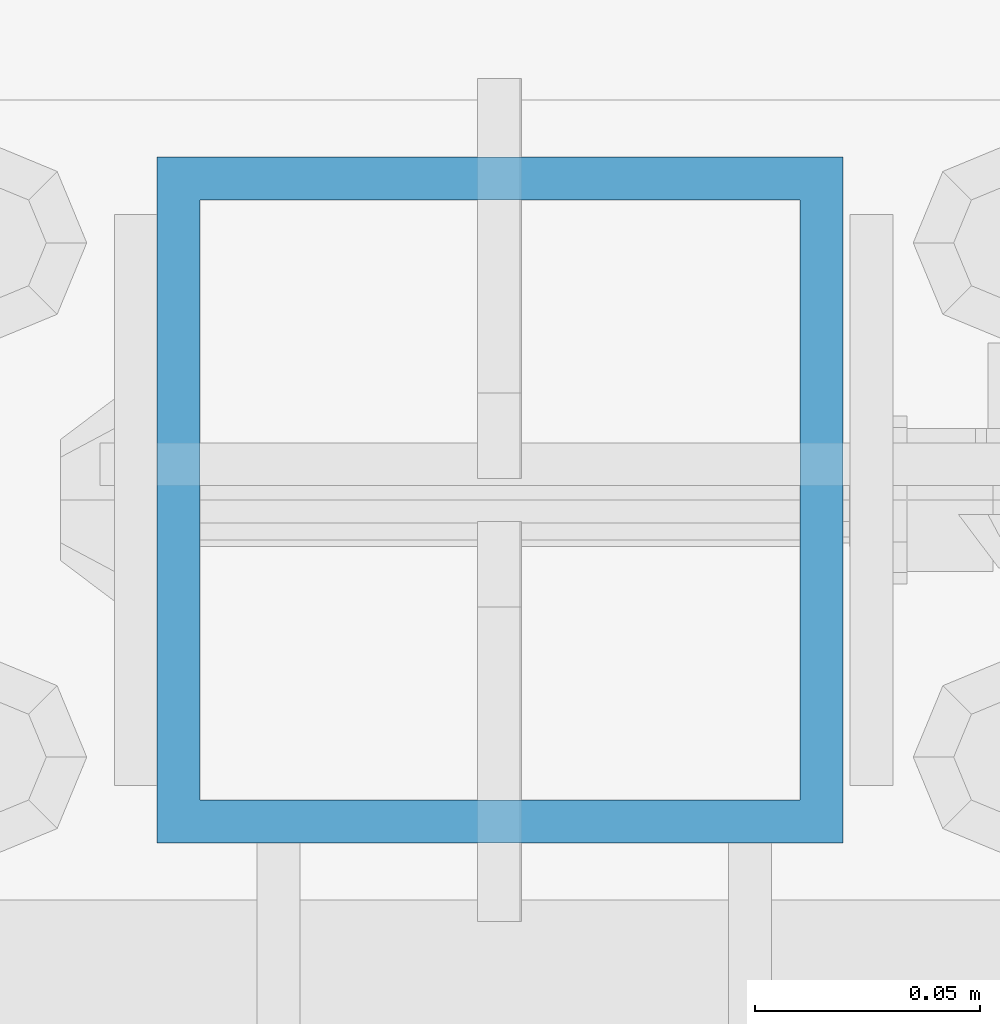
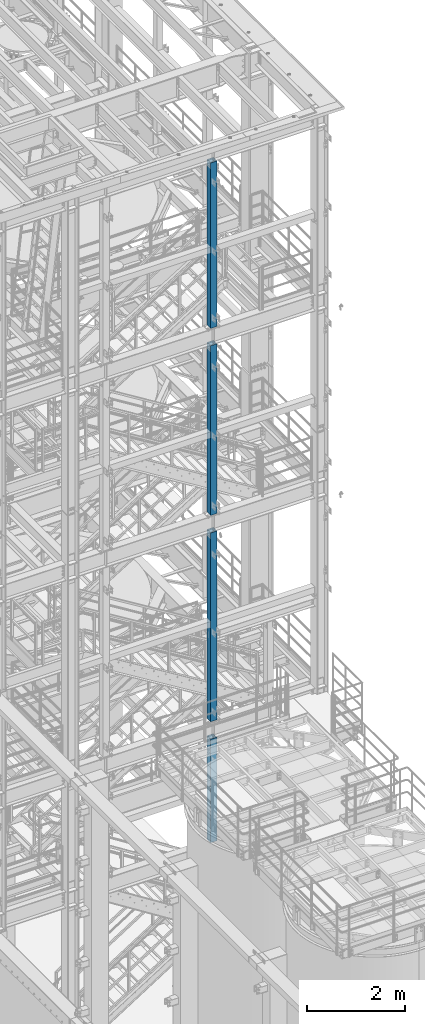
# One storey, part 579 of 1876: 4 columns, 4 elements without a shape of their own.
"""IFC2X3 building model written with IfcOpenShell, lengths in millimetres."""

from ifc_helpers import new_model, si_unit, frame, origin_with_axes, place, context, subcontext, project, spatial, faceted_brep, material, type_object, element, aggregate, save


model = new_model("IFC2X3")

# Units and contexts
model_context = context("Model", 3, precision=1e-05, world=origin_with_axes())
body_context = subcontext(model_context, "Body", "Model", "MODEL_VIEW")
ifc_project = project(units=[si_unit("LENGTHUNIT", "METRE", prefix="MILLI"), si_unit("AREAUNIT", "SQUARE_METRE"), si_unit("VOLUMEUNIT", "CUBIC_METRE"), si_unit("MASSUNIT", "GRAM", prefix="KILO"), si_unit("TIMEUNIT", "SECOND"), si_unit("PLANEANGLEUNIT", "RADIAN"), si_unit("SOLIDANGLEUNIT", "STERADIAN"), si_unit("THERMODYNAMICTEMPERATUREUNIT", "DEGREE_CELSIUS"), si_unit("LUMINOUSINTENSITYUNIT", "LUMEN")], contexts=[model_context])

# Site, building, storey
site_placement = place(None, origin_with_axes())
site = spatial("IfcSite", under=ifc_project, at=site_placement, CompositionType="ELEMENT")
building_placement = place(site_placement, origin_with_axes())
building = spatial("IfcBuilding", under=site, at=building_placement, Name="Undefined", CompositionType="ELEMENT")
storey_placement = place(building_placement, origin_with_axes())
storey = spatial("IfcBuildingStorey", under=building, at=storey_placement, Name="Undefined", CompositionType="ELEMENT", Elevation=0.0)

# Assembly, column
assembly_1_placement = place(storey_placement, origin_with_axes())
assembly_1 = element("IfcElementAssembly", 1, at=assembly_1_placement, inside=storey, Name="FRAME", AssemblyPlace="NOTDEFINED", PredefinedType="RIGID_FRAME")
ifc_material = material()
column_type = type_object("IfcColumnType", Name="HSS6X6X3/8", PredefinedType="NOTDEFINED")
column_1_placement = place(assembly_1_placement, frame((5080.0, -7112.0, 17983.2), z_axis=(-1.0, 0.0, 0.0), x_axis=(0.0, 0.0, 1.0)))
column_1 = element("IfcColumn", 2, at=column_1_placement, type_object=column_type, material=ifc_material, Name="COLUMN", ObjectType="HSS6X6X3/8", context=body_context, shape_type="Brep", body=[
    faceted_brep([(12.7000000000016, 66.6750000000002, -66.6750000000002), (12.7000000000016, -66.6750000000002, -66.6750000000002), (4149.72500000001, -66.6750000000002, -66.6750000000002), (4149.72500000001, 66.6750000000002, -66.6750000000002), (12.7000000000016, -66.6750000000002, 66.6750000000002), (4149.72500000001, -66.6750000000002, 66.6750000000002), (12.7000000000016, 66.6750000000002, 66.6750000000002), (4149.72500000001, 66.6750000000002, 66.6750000000002), (12.7000000000016, 76.1999999999998, -76.1999999999998), (12.7000000000016, 76.1999999999998, 76.1999999999998), (4149.72500000001, 76.1999999999998, 76.1999999999998), (4149.72500000001, 76.1999999999998, -76.1999999999998), (12.7000000000016, -76.1999999999998, 76.1999999999998), (4149.72500000001, -76.1999999999998, 76.1999999999998), (12.7000000000016, -76.1999999999998, -76.1999999999998), (4149.72500000001, -76.1999999999998, -76.1999999999998)], [[[0, 1, 2, 3]], [[1, 4, 5, 2]], [[4, 6, 7, 5]], [[6, 0, 3, 7]], [[8, 9, 10, 11]], [[9, 12, 13, 10]], [[12, 14, 15, 13]], [[14, 8, 11, 15]], [[13, 15, 11, 10], [5, 7, 3, 2]], [[14, 12, 9, 8], [6, 4, 1, 0]]]),
])
aggregate(assembly_1, [column_1])

assembly_2_placement = place(storey_placement, origin_with_axes())
assembly_2 = element("IfcElementAssembly", 3, at=assembly_2_placement, inside=storey, Name="FRAME", AssemblyPlace="NOTDEFINED", PredefinedType="RIGID_FRAME")
column_2_placement = place(assembly_2_placement, frame((5080.0, -7112.0, 13309.6), z_axis=(-1.0, 0.0, 0.0), x_axis=(0.0, 0.0, 1.0)))
column_2 = element("IfcColumn", 4, at=column_2_placement, type_object=column_type, material=ifc_material, Name="COLUMN", ObjectType="HSS6X6X3/8", context=body_context, shape_type="Brep", body=[
    faceted_brep([(12.7000000000016, 66.6750000000002, -66.6750000000002), (12.7000000000016, -66.6750000000002, -66.6750000000002), (4251.325, -66.6750000000002, -66.6750000000002), (4251.325, 66.6750000000002, -66.6750000000002), (12.7000000000016, -66.6750000000002, 66.6750000000002), (4251.325, -66.6750000000002, 66.6750000000002), (12.7000000000016, 66.6750000000002, 66.6750000000002), (4251.325, 66.6750000000002, 66.6750000000002), (12.7000000000016, 76.1999999999998, -76.1999999999998), (12.7000000000016, 76.1999999999998, 76.1999999999998), (4251.325, 76.1999999999998, 76.1999999999998), (4251.325, 76.1999999999998, -76.1999999999998), (12.7000000000016, -76.1999999999998, 76.1999999999998), (4251.325, -76.1999999999998, 76.1999999999998), (12.7000000000016, -76.1999999999998, -76.1999999999998), (4251.325, -76.1999999999998, -76.1999999999998)], [[[0, 1, 2, 3]], [[1, 4, 5, 2]], [[4, 6, 7, 5]], [[6, 0, 3, 7]], [[8, 9, 10, 11]], [[9, 12, 13, 10]], [[12, 14, 15, 13]], [[14, 8, 11, 15]], [[13, 15, 11, 10], [5, 7, 3, 2]], [[14, 12, 9, 8], [6, 4, 1, 0]]]),
])
aggregate(assembly_2, [column_2])

assembly_3_placement = place(storey_placement, origin_with_axes())
assembly_3 = element("IfcElementAssembly", 5, at=assembly_3_placement, inside=storey, Name="FRAME", AssemblyPlace="NOTDEFINED", PredefinedType="RIGID_FRAME")
column_3_placement = place(assembly_3_placement, frame((5080.0, -7112.0, 8153.4), z_axis=(-1.0, 0.0, 0.0), x_axis=(0.0, 0.0, 1.0)))
column_3 = element("IfcColumn", 6, at=column_3_placement, type_object=column_type, material=ifc_material, Name="COLUMN", ObjectType="HSS6X6X3/8", context=body_context, shape_type="Brep", body=[
    faceted_brep([(2062.16251831053, 1.58750109672837, 76.1999999999998), (2062.16251831053, 1.58750109672837, 66.6750000000002), (2062.16251831053, 14.2874999523192, 66.6750000000002), (2062.16251831053, 14.2874999523192, 76.1999999999998), (2217.73749999998, 14.2874999523192, 66.6750000000002), (2217.73749999998, 14.2874999523192, 76.1999999999998), (2217.73749999998, 1.58750109672837, 66.6750000000002), (2217.73749999998, 1.58750109672837, 76.1999999999998), (2062.16251831053, 1.58750109672837, -66.6750000000002), (2062.16251831053, 1.58750109672837, -76.1999999999998), (2062.16251831053, 14.2874999523192, -76.1999999999998), (2062.16251831053, 14.2874999523192, -66.6750000000002), (2217.73749999998, 14.2874999523192, -76.1999999999998), (2217.73749999998, 14.2874999523192, -66.6750000000002), (2217.73749999998, 1.58750109672837, -76.1999999999998), (2217.73749999998, 1.58750109672837, -66.6750000000002), (12.7000000000016, -76.1999999999998, 76.1999999999998), (12.7000000000016, -76.1999999999998, -76.1999999999998), (4733.925, -76.1999999999998, -76.1999999999998), (4733.925, -76.1999999999998, 76.1999999999998), (12.7000000000016, 76.1999999999998, 76.1999999999998), (4733.925, 76.1999999999998, 76.1999999999998), (12.7000000000016, 76.1999999999998, -76.1999999999998), (4733.925, 76.1999999999998, -76.1999999999998), (12.7000000000016, 66.6750000000002, 66.6750000000002), (12.7000000000016, -66.6750000000002, 66.6750000000002), (12.7000000000016, -66.6750000000002, -66.6750000000002), (12.7000000000016, 66.6750000000002, -66.6750000000002), (4733.925, 66.6750000000002, -66.6750000000002), (4733.925, 66.6750000000002, 66.6750000000002), (4733.925, -66.6750000000002, 66.6750000000002), (4733.925, -66.6750000000002, -66.6750000000002)], [[[0, 1, 2, 3]], [[3, 2, 4, 5]], [[5, 4, 6, 7]], [[7, 6, 1, 0]], [[8, 9, 10, 11]], [[11, 10, 12, 13]], [[13, 12, 14, 15]], [[15, 14, 9, 8]], [[16, 17, 18, 19]], [[20, 16, 19, 21], [3, 5, 7, 0]], [[22, 20, 21, 23]], [[17, 16, 20, 22], [24, 25, 26, 27]], [[24, 27, 28, 29]], [[25, 24, 29, 30], [2, 1, 6, 4]], [[26, 25, 30, 31]], [[27, 26, 31, 28], [11, 13, 15, 8]], [[19, 18, 23, 21], [30, 29, 28, 31]], [[17, 22, 23, 18], [10, 9, 14, 12]]]),
])
aggregate(assembly_3, [column_3])

assembly_4_placement = place(storey_placement, origin_with_axes())
assembly_4 = element("IfcElementAssembly", 7, at=assembly_4_placement, inside=storey, Name="FRAME", AssemblyPlace="NOTDEFINED", PredefinedType="RIGID_FRAME")
column_4_placement = place(assembly_4_placement, frame((5080.0, -7112.0, 5130.8), z_axis=(-1.0, 0.0, 0.0), x_axis=(0.0, 0.0, 1.0)))
column_4 = element("IfcColumn", 8, at=column_4_placement, type_object=column_type, material=ifc_material, Name="COLUMN", ObjectType="HSS6X6X3/8", context=body_context, shape_type="Brep", body=[
    faceted_brep([(12.7000000000016, 66.6750000000002, -66.6750000000002), (12.7000000000016, -66.6750000000002, -66.6750000000002), (2600.325, -66.6750000000002, -66.6750000000002), (2600.325, 66.6750000000002, -66.6750000000002), (12.7000000000016, -66.6750000000002, 66.6750000000002), (2600.325, -66.6750000000002, 66.6750000000002), (12.7000000000016, 66.6750000000002, 66.6750000000002), (2600.325, 66.6750000000002, 66.6750000000002), (12.7000000000016, 76.1999999999998, -76.1999999999998), (12.7000000000016, 76.1999999999998, 76.1999999999998), (2600.325, 76.1999999999998, 76.1999999999998), (2600.325, 76.1999999999998, -76.1999999999998), (12.7000000000016, -76.1999999999998, 76.1999999999998), (2600.325, -76.1999999999998, 76.1999999999998), (12.7000000000016, -76.1999999999998, -76.1999999999998), (2600.325, -76.1999999999998, -76.1999999999998)], [[[0, 1, 2, 3]], [[1, 4, 5, 2]], [[4, 6, 7, 5]], [[6, 0, 3, 7]], [[8, 9, 10, 11]], [[9, 12, 13, 10]], [[12, 14, 15, 13]], [[14, 8, 11, 15]], [[13, 15, 11, 10], [5, 7, 3, 2]], [[14, 12, 9, 8], [6, 4, 1, 0]]]),
])
aggregate(assembly_4, [column_4])

save(model, "model.ifc")
